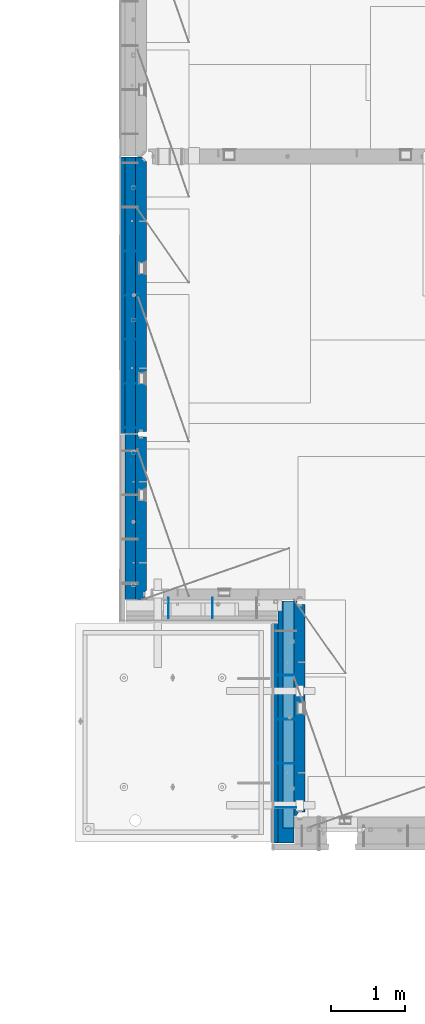
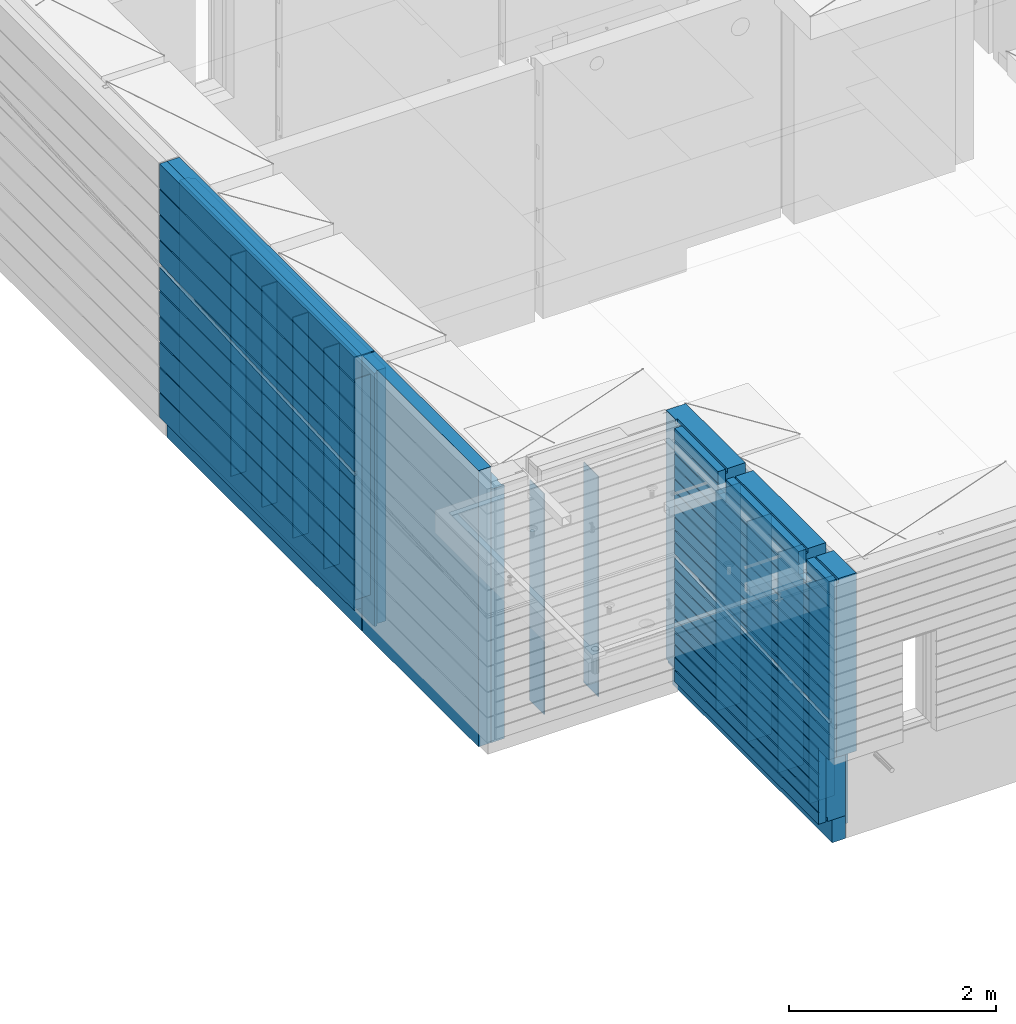
# One storey, part 208 of 325: 20 walls, 4 elements without a shape of their own.
"""IFC2X3 building model written with IfcOpenShell, lengths in millimetres."""

from ifc_helpers import new_model, si_unit, frame, origin_with_axes, place, context, subcontext, project, spatial, faceted_brep, material, type_object, element, aggregate, save


model = new_model("IFC2X3")

# Units and contexts
model_context = context("Model", 3, precision=1e-05, world=origin_with_axes())
body_context = subcontext(model_context, "Body", "Model", "MODEL_VIEW")
ifc_project = project(units=[si_unit("LENGTHUNIT", "METRE", prefix="MILLI"), si_unit("AREAUNIT", "SQUARE_METRE"), si_unit("VOLUMEUNIT", "CUBIC_METRE"), si_unit("MASSUNIT", "GRAM", prefix="KILO"), si_unit("TIMEUNIT", "SECOND"), si_unit("PLANEANGLEUNIT", "RADIAN"), si_unit("SOLIDANGLEUNIT", "STERADIAN"), si_unit("THERMODYNAMICTEMPERATUREUNIT", "DEGREE_CELSIUS"), si_unit("LUMINOUSINTENSITYUNIT", "LUMEN")], contexts=[model_context])

# Site, building, storey
site_placement = place(None, origin_with_axes())
site = spatial("IfcSite", under=ifc_project, at=site_placement, CompositionType="ELEMENT")
building_placement = place(site_placement, origin_with_axes())
building = spatial("IfcBuilding", under=site, at=building_placement, CompositionType="ELEMENT")
storey_placement = place(building_placement, origin_with_axes())
storey = spatial("IfcBuildingStorey", under=building, at=storey_placement, Name="1", CompositionType="ELEMENT", Elevation=0.0)

# Assembly, walls
assembly_1_placement = place(storey_placement, origin_with_axes())
assembly_1 = element("IfcElementAssembly", 1, at=assembly_1_placement, inside=storey, AssemblyPlace="NOTDEFINED", PredefinedType="REINFORCEMENT_UNIT")
ifc_material_1 = material(Name="Undefined")
wall_type_1 = type_object("IfcWallType", PredefinedType="NOTDEFINED")
wall_1_placement = place(assembly_1_placement, frame((7880.0, 15690.0, 83115.0), z_axis=(0.0, 0.0, 1.0), x_axis=(-1.0, 3.00000001838171e-08, 0.0)))
wall_1 = element("IfcWall", 2, at=wall_1_placement, type_object=wall_type_1, material=ifc_material_1, Name="(PD)", context=body_context, shape_type="Brep", body=[
    faceted_brep([(0.0, 5.0, -1300.0), (0.0, 5.0, 1300.0), (200.0, 5.0, 1300.0), (200.0, 5.0, -1300.0), (0.0, -5.0, 1300.0), (200.0, -5.0, 1300.0), (0.0, -5.0, -1300.0), (200.0, -5.0, -1300.0)], [[[0, 1, 2, 3]], [[1, 4, 5, 2]], [[4, 6, 7, 5]], [[6, 0, 3, 7]], [[5, 7, 3, 2]], [[6, 4, 1, 0]]]),
])
wall_2_placement = place(assembly_1_placement, frame((7880.0, 15090.0, 83115.0), z_axis=(0.0, 0.0, 1.0), x_axis=(-1.0, 3.00000001838171e-08, 0.0)))
wall_2 = element("IfcWall", 3, at=wall_2_placement, type_object=wall_type_1, material=ifc_material_1, Name="(PD)", context=body_context, shape_type="Brep", body=[
    faceted_brep([(0.0, 5.0, -1300.0), (0.0, 5.0, 1300.0), (200.0, 5.0, 1300.0), (200.0, 5.0, -1300.0), (0.0, -5.0, 1300.0), (200.0, -5.0, 1300.0), (0.0, -5.0, -1300.0), (200.0, -5.0, -1300.0)], [[[0, 1, 2, 3]], [[1, 4, 5, 2]], [[4, 6, 7, 5]], [[6, 0, 3, 7]], [[5, 7, 3, 2]], [[6, 4, 1, 0]]]),
])
wall_3_placement = place(assembly_1_placement, frame((7880.0, 14490.0, 83115.0), z_axis=(0.0, 0.0, 1.0), x_axis=(-1.0, 3.00000001838171e-08, 0.0)))
wall_3 = element("IfcWall", 4, at=wall_3_placement, type_object=wall_type_1, material=ifc_material_1, Name="(PD)", context=body_context, shape_type="Brep", body=[
    faceted_brep([(0.0, 5.0, -1300.0), (0.0, 5.0, 1300.0), (200.0, 5.0, 1300.0), (200.0, 5.0, -1300.0), (0.0, -5.0, 1300.0), (200.0, -5.0, 1300.0), (0.0, -5.0, -1300.0), (200.0, -5.0, -1300.0)], [[[0, 1, 2, 3]], [[1, 4, 5, 2]], [[4, 6, 7, 5]], [[6, 0, 3, 7]], [[5, 7, 3, 2]], [[6, 4, 1, 0]]]),
])
wall_4_placement = place(assembly_1_placement, frame((7880.0, 13890.0, 83115.0), z_axis=(0.0, 0.0, 1.0), x_axis=(-1.0, 3.00000001838171e-08, 0.0)))
wall_4 = element("IfcWall", 5, at=wall_4_placement, type_object=wall_type_1, material=ifc_material_1, Name="(PD)", context=body_context, shape_type="Brep", body=[
    faceted_brep([(0.0, 5.0, -1300.0), (0.0, 5.0, 1300.0), (200.0, 5.0, 1300.0), (200.0, 5.0, -1300.0), (0.0, -5.0, 1300.0), (200.0, -5.0, 1300.0), (0.0, -5.0, -1300.0), (200.0, -5.0, -1300.0)], [[[0, 1, 2, 3]], [[1, 4, 5, 2]], [[4, 6, 7, 5]], [[6, 0, 3, 7]], [[5, 7, 3, 2]], [[6, 4, 1, 0]]]),
])
wall_5_placement = place(assembly_1_placement, frame((7880.0, 13290.0, 83115.0), z_axis=(0.0, 0.0, 1.0), x_axis=(-1.0, 3.00000001838171e-08, 0.0)))
wall_5 = element("IfcWall", 6, at=wall_5_placement, type_object=wall_type_1, material=ifc_material_1, Name="(PD)", context=body_context, shape_type="Brep", body=[
    faceted_brep([(0.0, 5.0, -1300.0), (0.0, 5.0, 1300.0), (200.0, 5.0, 1300.0), (200.0, 5.0, -1300.0), (0.0, -5.0, 1300.0), (200.0, -5.0, 1300.0), (0.0, -5.0, -1300.0), (200.0, -5.0, -1300.0)], [[[0, 1, 2, 3]], [[1, 4, 5, 2]], [[4, 6, 7, 5]], [[6, 0, 3, 7]], [[5, 7, 3, 2]], [[6, 4, 1, 0]]]),
])

assembly_2_placement = place(storey_placement, origin_with_axes())
assembly_2 = element("IfcElementAssembly", 7, at=assembly_2_placement, inside=storey, AssemblyPlace="NOTDEFINED", PredefinedType="REINFORCEMENT_UNIT")
wall_6_placement = place(assembly_2_placement, frame((8300.0, 10980.0, 83115.0), z_axis=(0.0, 0.0, 1.0), x_axis=(0.0, -1.0, 0.0)))
wall_6 = element("IfcWall", 8, at=wall_6_placement, type_object=wall_type_1, material=ifc_material_1, Name="(PD)", context=body_context, shape_type="Brep", body=[
    faceted_brep([(0.0, 5.0, -1300.0), (0.0, 5.0, 1300.0), (280.0, 5.0, 1300.0), (280.0, 5.0, -1300.0), (0.0, -5.0, 1300.0), (280.0, -5.0, 1300.0), (0.0, -5.0, -1300.0), (280.0, -5.0, -1300.0)], [[[0, 1, 2, 3]], [[1, 4, 5, 2]], [[4, 6, 7, 5]], [[6, 0, 3, 7]], [[5, 7, 3, 2]], [[6, 4, 1, 0]]]),
])
wall_7_placement = place(assembly_2_placement, frame((8900.0, 10980.0, 83115.0), z_axis=(0.0, 0.0, 1.0), x_axis=(0.0, -1.0, 0.0)))
wall_7 = element("IfcWall", 9, at=wall_7_placement, type_object=wall_type_1, material=ifc_material_1, Name="(PD)", context=body_context, shape_type="Brep", body=[
    faceted_brep([(0.0, 5.0, -1300.0), (0.0, 5.0, 1300.0), (280.0, 5.0, 1300.0), (280.0, 5.0, -1300.0), (0.0, -5.0, 1300.0), (280.0, -5.0, 1300.0), (0.0, -5.0, -1300.0), (280.0, -5.0, -1300.0)], [[[0, 1, 2, 3]], [[1, 4, 5, 2]], [[4, 6, 7, 5]], [[6, 0, 3, 7]], [[5, 7, 3, 2]], [[6, 4, 1, 0]]]),
])
aggregate(assembly_2, [wall_6, wall_7])

assembly_3_placement = place(storey_placement, origin_with_axes())
assembly_3 = element("IfcElementAssembly", 10, at=assembly_3_placement, inside=storey, AssemblyPlace="NOTDEFINED", PredefinedType="REINFORCEMENT_UNIT")
wall_8_placement = place(assembly_3_placement, frame((10040.0, 9925.0, 83115.0), z_axis=(0.0, 0.0, 1.0), x_axis=(-1.0, 3.00000001838171e-08, 0.0)))
wall_8 = element("IfcWall", 11, at=wall_8_placement, type_object=wall_type_1, material=ifc_material_1, Name="(PD)", context=body_context, shape_type="Brep", body=[
    faceted_brep([(0.0, 5.0, -1300.0), (0.0, 5.0, 1300.0), (280.0, 5.0, 1300.0), (280.0, 5.0, -1300.0), (0.0, -5.0, 1300.0), (280.0, -5.0, 1300.0), (0.0, -5.0, -1300.0), (280.0, -5.0, -1300.0)], [[[0, 1, 2, 3]], [[1, 4, 5, 2]], [[4, 6, 7, 5]], [[6, 0, 3, 7]], [[5, 7, 3, 2]], [[6, 4, 1, 0]]]),
])
wall_9_placement = place(assembly_3_placement, frame((10040.0, 9325.0, 83115.0), z_axis=(0.0, 0.0, 1.0), x_axis=(-1.0, 3.00000001838171e-08, 0.0)))
wall_9 = element("IfcWall", 12, at=wall_9_placement, type_object=wall_type_1, material=ifc_material_1, Name="(PD)", context=body_context, shape_type="Brep", body=[
    faceted_brep([(0.0, 5.0, -1300.0), (0.0, 5.0, 1300.0), (280.0, 5.0, 1300.0), (280.0, 5.0, -1300.0), (0.0, -5.0, 1300.0), (280.0, -5.0, 1300.0), (0.0, -5.0, -1300.0), (280.0, -5.0, -1300.0)], [[[0, 1, 2, 3]], [[1, 4, 5, 2]], [[4, 6, 7, 5]], [[6, 0, 3, 7]], [[5, 7, 3, 2]], [[6, 4, 1, 0]]]),
])
wall_10_placement = place(assembly_3_placement, frame((10040.0, 8725.0, 83115.0), z_axis=(0.0, 0.0, 1.0), x_axis=(-1.0, 3.00000001838171e-08, 0.0)))
wall_10 = element("IfcWall", 13, at=wall_10_placement, type_object=wall_type_1, material=ifc_material_1, Name="(PD)", context=body_context, shape_type="Brep", body=[
    faceted_brep([(0.0, 5.0, -1300.0), (0.0, 5.0, 1300.0), (280.0, 5.0, 1300.0), (280.0, 5.0, -1300.0), (0.0, -5.0, 1300.0), (280.0, -5.0, 1300.0), (0.0, -5.0, -1300.0), (280.0, -5.0, -1300.0)], [[[0, 1, 2, 3]], [[1, 4, 5, 2]], [[4, 6, 7, 5]], [[6, 0, 3, 7]], [[5, 7, 3, 2]], [[6, 4, 1, 0]]]),
])
wall_11_placement = place(assembly_3_placement, frame((10040.0, 8125.0, 83115.0), z_axis=(0.0, 0.0, 1.0), x_axis=(-1.0, 3.00000001838171e-08, 0.0)))
wall_11 = element("IfcWall", 14, at=wall_11_placement, type_object=wall_type_1, material=ifc_material_1, Name="(PD)", context=body_context, shape_type="Brep", body=[
    faceted_brep([(0.0, 5.0, -1300.0), (0.0, 5.0, 1300.0), (280.0, 5.0, 1300.0), (280.0, 5.0, -1300.0), (0.0, -5.0, 1300.0), (280.0, -5.0, 1300.0), (0.0, -5.0, -1300.0), (280.0, -5.0, -1300.0)], [[[0, 1, 2, 3]], [[1, 4, 5, 2]], [[4, 6, 7, 5]], [[6, 0, 3, 7]], [[5, 7, 3, 2]], [[6, 4, 1, 0]]]),
])
ifc_material_2 = material(Name="COS5gt")
wall_type_2 = type_object("IfcWallType", PredefinedType="NOTDEFINED")
wall_12_placement = place(assembly_3_placement, frame((9900.0, 8000.0, 83247.5), z_axis=(0.0, 0.0, 1.0), x_axis=(0.0, 1.0, 0.0)))
wall_12 = element("IfcWall", 15, at=wall_12_placement, type_object=wall_type_2, material=ifc_material_2, context=body_context, shape_type="Brep", body=[
    faceted_brep([(-150.0, -110.0, -607.5), (-150.0, 110.0, -607.5), (-150.0, 110.0, -1442.5), (-150.0, 90.0, -1442.5), (-150.0, 90.0, -1492.5), (-150.0, -110.0, -1492.5), (-355.0, -110.0, -607.5), (-355.0, 110.0, -607.5), (2751.0, 90.0, 1492.5), (2751.0, 90.0, 1442.5), (1785.0, 90.0, 1442.5), (1785.0, 90.0, 1492.5), (2751.0, 110.0, 1492.5), (2751.0, 110.0, 1442.5), (1785.0, 110.0, 1442.5), (1635.0, -110.0, 1492.5), (1635.0, 90.0, 1492.5), (229.999999999998, 90.0, 1492.5), (229.999999999998, -110.0, 1492.5), (1635.0, 90.0, 1442.5), (1635.0, 110.0, 1442.5), (229.999999999998, 110.0, 1442.5), (229.999999999998, 90.0, 1442.5), (-355.0, 110.0, 1442.5), (-355.0, 90.0, 1442.5), (79.9999999999982, 90.0, 1442.5), (79.9999999999982, 110.0, 1442.5), (-355.0, 90.0, 1492.5), (-355.0, -110.0, 1492.5), (79.9999999999982, -110.0, 1492.5), (79.9999999999982, 90.0, 1492.5), (79.9999999999982, -110.0, 1222.5), (79.9999999999982, 110.0, 1222.5), (229.999999999998, -110.0, 1222.5), (229.999999999998, 110.0, 1222.5), (1635.0, -110.0, 1222.5), (1635.0, 110.0, 1222.5), (1785.0, -110.0, 1222.5), (1785.0, 110.0, 1222.5), (1785.0, -110.0, 1492.5), (2935.0, -110.0, 1492.5), (2935.0, 110.0, 1492.5), (2935.0, -110.0, -1492.5), (2935.0, 90.0, -1492.5), (2935.0, 90.0, -1442.5), (2935.0, 110.0, -1442.5)], [[[0, 1, 2, 3, 4, 5]], [[6, 7, 1, 0]], [[8, 9, 10, 11]], [[12, 13, 9, 8]], [[9, 13, 14, 10]], [[15, 16, 17, 18]], [[19, 20, 21, 22]], [[23, 24, 25, 26]], [[27, 28, 29, 30]], [[24, 27, 30, 25]], [[29, 31, 32, 26, 25, 30]], [[33, 34, 32, 31]], [[18, 17, 22, 21, 34, 33]], [[16, 19, 22, 17]], [[15, 35, 36, 20, 19, 16]], [[37, 38, 36, 35]], [[39, 11, 10, 14, 38, 37]], [[40, 41, 12, 8, 11, 39]], [[41, 40, 42, 43, 44, 45]], [[43, 42, 5, 4]], [[44, 43, 4, 3]], [[45, 44, 3, 2]], [[23, 26, 32, 34, 21, 20, 36, 38, 14, 13, 12, 41, 45, 2, 1, 7]], [[28, 27, 24, 23, 7, 6]], [[42, 40, 39, 37, 35, 15, 18, 33, 31, 29, 28, 6, 0, 5]]]),
])

# Wall
ifc_material_3 = material(Name="CONCRETE/C30/37")
wall_type_3 = type_object("IfcWallType", PredefinedType="NOTDEFINED")
wall_13_placement = place(assembly_1_placement, frame((7667.5, 13210.0, 83247.5), z_axis=(0.0, 0.0, 1.0), x_axis=(0.0, 1.0, 0.0)))
wall_13 = element("IfcWall", 16, at=wall_13_placement, type_object=wall_type_3, material=ifc_material_3, context=body_context, shape_type="Brep", body=[
    faceted_brep([(3759.9500004017, 42.5, 276.327823387459), (0.0, 42.5, 92.631582698581), (4.04732254537521e-05, 12.4999999999927, 92.631582698581), (3759.95000031049, 12.4999999999927, 276.327823387459), (3759.9500004017, 12.4999999999927, 326.327823080399), (9.0334564447403e-05, 12.4999999999927, 142.631584822841), (0.0, 42.5, 142.631584822841), (3077.78608245648, 42.5, 292.999999944761), (3118.72268571102, 32.4999992501689, 294.999999999229), (3323.40570462213, 32.4999991121731, 305.00000040044), (3364.34229629902, 42.5, 306.999999889245), (3759.9500004017, 42.5, 326.327823080399), (3759.9500004017, 32.4999991121731, 5.0000004004396), (0.0, 32.4999991127006, 5.0000004004396), (0.0, 42.5, 6.99999988924537), (3759.9500004017, 42.5, 6.99999988924537), (3759.9500004017, 32.4999992501689, -5.00000000077125), (0.0, 32.4999992507037, -5.00000000074215), (3759.9500004017, 42.5, -7.00000005523907), (0.0, 42.5, -7.00000005523907), (3759.9500004017, 42.5, -293.000000110755), (0.0, 42.5, -293.000000110755), (3759.9500004017, 32.4999991121731, -294.99999959956), (0.0, 32.4999991127006, -294.99999959956), (3759.9500004017, 32.4999992501689, -305.000000000771), (0.0, 32.4999992507037, -305.000000000742), (3759.9500004017, 42.5, -307.000000055239), (0.0, 42.5, -307.000000055239), (3759.9500004017, 42.5, -593.000000110755), (0.0, 42.5, -593.000000110755), (3759.9500004017, 32.4999991121731, -594.99999959956), (3.63797880709171e-12, 32.4999991127006, -594.99999959956), (3759.9500004017, 32.4999992501689, -605.000000000771), (3.63797880709171e-12, 32.4999992507037, -605.000000000742), (3759.9500004017, 42.5, -607.000000055239), (0.0, 42.5, -607.000000055239), (3759.9500004017, 42.5, -893.000000110755), (0.0, 42.5, -893.000000110755), (3759.9500004017, 32.4999991121731, -894.99999959956), (0.0, 32.4999991127006, -894.99999959956), (3759.9500004017, 32.4999992501689, -905.000000000771), (0.0, 32.4999992507037, -905.000000000742), (3759.9500004017, 42.5, -907.000000055239), (0.0, 42.5, -907.000000055239), (3759.9500004017, 42.5, -1193.00000011075), (0.0, 42.5, -1193.00000011075), (3759.9500004017, 32.4999991121731, -1194.99999959956), (0.0, 32.4999991127006, -1194.99999959956), (3759.9500004017, 32.4999992501689, -1205.00000000077), (0.0, 32.4999992507037, -1205.00000000074), (3759.9500004017, 42.5, -1207.00000005524), (0.0, 42.5, -1207.00000005524), (3759.9500004017, 42.5, -1492.5), (0.0, 42.5, -1492.5), (0.0, -42.5, -1492.5), (3759.9500004017, -42.5, -1492.5), (0.0, -42.5, 1492.5), (3759.9500004017, -42.5, 1492.5), (0.0, 42.5, 1492.5), (3759.9500004017, 42.5, 1492.5), (3759.9500004017, 42.5, 1206.99999988925), (0.0, 42.5, 1206.99999988925), (3759.9500004017, 32.4999991121731, 1205.00000040044), (0.0, 32.4999991127006, 1205.00000040044), (3759.9500004017, 32.4999992501689, 1194.99999999923), (0.0, 32.4999992507037, 1194.99999999926), (3759.9500004017, 42.5, 1192.99999994476), (0.0, 42.5, 1192.99999994476), (3759.9500004017, 42.5, 906.999999889245), (0.0, 42.5, 906.999999889245), (3759.9500004017, 32.4999991121731, 905.00000040044), (0.0, 32.4999991127006, 905.00000040044), (3759.9500004017, 32.4999992501689, 894.999999999229), (0.0, 32.4999992507037, 894.999999999258), (3759.9500004017, 42.5, 892.999999944761), (0.0, 42.5, 892.999999944761), (3759.9500004017, 42.5, 606.999999889245), (0.0, 42.5, 606.999999889245), (3759.9500004017, 32.4999991121731, 605.00000040044), (3.63797880709171e-12, 32.4999991127006, 605.00000040044), (3759.9500004017, 32.4999992501689, 594.999999999229), (3.63797880709171e-12, 32.4999992507037, 594.999999999258), (3759.9500004017, 42.5, 592.999999944761), (0.0, 42.5, 592.999999944761), (0.0, 42.5, 306.999999889245), (-3.63797880709171e-12, 32.4999991127006, 305.00000040044), (-3.63797880709171e-12, 32.4999992507037, 294.999999999258), (0.0, 42.5, 292.999999944761)], [[[0, 1, 2, 3]], [[4, 5, 6, 7, 8, 9, 10, 11]], [[3, 2, 5, 4]], [[12, 13, 14, 15]], [[16, 17, 13, 12]], [[18, 19, 17, 16]], [[20, 21, 19, 18]], [[22, 23, 21, 20]], [[24, 25, 23, 22]], [[26, 27, 25, 24]], [[28, 29, 27, 26]], [[30, 31, 29, 28]], [[32, 33, 31, 30]], [[34, 35, 33, 32]], [[36, 37, 35, 34]], [[38, 39, 37, 36]], [[40, 41, 39, 38]], [[42, 43, 41, 40]], [[44, 45, 43, 42]], [[46, 47, 45, 44]], [[48, 49, 47, 46]], [[50, 51, 49, 48]], [[52, 53, 51, 50]], [[54, 53, 52, 55]], [[56, 54, 55, 57]], [[58, 56, 57, 59]], [[58, 59, 60, 61]], [[62, 63, 61, 60]], [[64, 65, 63, 62]], [[66, 67, 65, 64]], [[68, 69, 67, 66]], [[70, 71, 69, 68]], [[72, 73, 71, 70]], [[74, 75, 73, 72]], [[76, 77, 75, 74]], [[78, 79, 77, 76]], [[80, 81, 79, 78]], [[82, 83, 81, 80]], [[84, 83, 82, 11, 10]], [[85, 84, 10, 9]], [[86, 85, 9, 8]], [[87, 86, 8, 7]], [[87, 7, 6]], [[1, 14, 13, 17, 19, 21, 23, 25, 27, 29, 31, 33, 35, 37, 39, 41, 43, 45, 47, 49, 51, 53, 54, 56, 58, 61, 63, 65, 67, 69, 71, 73, 75, 77, 79, 81, 83, 84, 85, 86, 87, 6, 5, 2]], [[15, 14, 1, 0]], [[82, 80, 78, 76, 74, 72, 70, 68, 66, 64, 62, 60, 59, 57, 55, 52, 50, 48, 46, 44, 42, 40, 38, 36, 34, 32, 30, 28, 26, 24, 22, 20, 18, 16, 12, 15, 0, 3, 4, 11]]]),
])

wall_14_placement = place(assembly_3_placement, frame((9747.5, 8000.0, 83247.5), z_axis=(0.0, 0.0, 1.0), x_axis=(0.0, 1.0, 0.0)))
wall_14 = element("IfcWall", 17, at=wall_14_placement, type_object=wall_type_3, material=ifc_material_3, context=body_context, shape_type="Brep", body=[
    faceted_brep([(2630.0, 42.5, -33.4213325430028), (386.991957076316, 42.5, -143.000000110769), (346.053195555138, 32.4999991164314, -144.999999599575), (141.359327417116, 32.4999992544253, -155.0000000008), (100.420554317418, 42.5, -157.000000055254), (-355.0, 42.5, -179.248862550885), (-354.999999999999, 12.4999999999982, -179.248862550885), (2630.00000006686, 12.4999999999982, -33.4213325430028), (2630.0, 12.4999999999982, 16.5473755983112), (-354.999999999999, 12.4999999999982, -129.249877626527), (-355.0, 42.5, -129.249877626527), (2147.89958472361, 42.5, -7.00000005523907), (2188.84685931518, 32.4999992500489, -5.00000000080036), (2393.58323491501, 32.4999991120476, 5.00000040042505), (2434.53049792634, 42.5, 6.99999988924537), (2630.0, 42.5, 16.5786657067802), (-355.0, 42.5, 1342.99999994476), (-355.0, 32.4999992499324, 1344.99999999921), (79.9999999999982, 32.4999992499324, 1344.99999999921), (79.9999999999982, 42.5, 1342.99999994476), (-355.0, 32.4999991119385, 1355.00000040044), (79.9999999999982, 32.4999991119385, 1355.00000040044), (-355.0, 42.5, 1356.99999988925), (79.9999999999982, 42.5, 1356.99999988925), (2630.0, -42.5, 1492.5), (2630.0, 42.5, 1492.5), (1785.0, 42.5, 1492.5), (1785.0, -42.5, 1492.5), (2630.0, 42.5, 1356.99999988925), (1785.0, 42.5, 1356.99999988925), (2630.0, 32.4999991119385, 1355.00000040044), (1785.0, 32.4999991119385, 1355.00000040044), (2630.0, 32.4999992499324, 1344.99999999921), (1785.0, 32.4999992499324, 1344.99999999921), (2630.0, 42.5, 1342.99999994476), (1785.0, 42.5, 1342.99999994476), (1785.0, 42.5, 1222.5), (1785.0, -42.5, 1222.5), (1635.0, 42.5, 1222.5), (1635.0, -42.5, 1222.5), (1635.0, -42.5, 1492.5), (1635.0, 42.5, 1342.99999994476), (1635.0, 32.4999992499324, 1344.99999999921), (1635.0, 32.4999991119385, 1355.00000040044), (1635.0, 42.5, 1356.99999988925), (1635.0, 42.5, 1492.5), (229.999999999998, 42.5, 1342.99999994476), (229.999999999998, 32.4999992499324, 1344.99999999921), (229.999999999998, 32.4999991119385, 1355.00000040044), (229.999999999998, 42.5, 1356.99999988925), (229.999999999998, 42.5, 1492.5), (229.999999999998, -42.5, 1492.5), (2630.0, 32.4999991158911, -294.999999599575), (-355.0, 32.4999991158911, -294.999999599575), (-355.0, 42.5, -293.000000110755), (2630.0, 42.5, -293.000000110755), (2630.0, 32.4999992538942, -305.0000000008), (-355.0, 32.4999992538942, -305.0000000008), (2630.0, 42.5, -307.000000055239), (-355.0, 42.5, -307.000000055239), (2630.0, 42.5, -443.00000011074), (-355.0, 42.5, -443.00000011074), (2630.0, 32.499999114294, -444.99999959956), (-355.000000000001, 32.499999114294, -444.99999959956), (2630.0, 32.4999992522953, -455.000000000786), (-355.000000000001, 32.4999992522953, -455.000000000786), (2630.0, 42.5, -457.000000055225), (-355.0, 42.5, -457.000000055225), (-150.0, 42.4999992447574, -593.00000011074), (-150.0, 32.4999991142904, -594.99999959956), (-150.0, 32.4999992523008, -605.000000000757), (-150.0, 42.4999992696412, -607.000000055225), (2630.0, 32.499999114294, -594.99999959956), (2630.0, 42.5, -593.00000011074), (2630.0, 32.4999992522953, -605.000000000786), (2630.0, 42.5, -607.000000055225), (-355.0, -42.5, -607.5), (-355.0, 42.5, -607.5), (-150.000000000005, 42.4999997380673, -607.5), (-150.000000000005, -42.5, -607.5), (2630.0, 42.5, -743.00000011074), (-150.000000000005, 42.4999992461126, -743.00000011074), (2630.0, 32.499999114294, -744.99999959956), (-150.000000000005, 32.4999991142904, -744.99999959956), (2630.0, 32.4999992522953, -755.000000000786), (-150.000000000005, 32.4999992523008, -755.000000000757), (2630.0, 42.5, -757.000000055225), (-150.000000000005, 42.4999992709527, -757.000000055225), (2630.0, 42.5, -893.00000011074), (-150.000000000005, 42.4999992456051, -893.00000011074), (2630.0, 32.4999991137665, -894.99999959956), (-150.000000000005, 32.4999991137774, -894.999999599546), (2630.0, 32.4999992517678, -905.000000000786), (-150.000000000005, 32.4999992517769, -905.000000000742), (2630.0, 42.5, -907.000000055225), (-150.000000000005, 42.4999992704252, -907.000000055225), (2630.0, 42.5, -1043.00000011077), (-150.000000000005, 42.4999992450466, -1043.00000011077), (2630.0, 32.4999991132281, -1044.99999959959), (-150.000000000005, 32.4999991132208, -1044.99999959959), (2630.0, 32.4999992512294, -1055.00000000081), (-150.000000000005, 32.499999251233, -1055.00000000079), (2630.0, 42.5, -1057.00000005525), (-150.000000000005, 42.4999992698868, -1057.00000005525), (2630.0, 42.5, -1193.00000011075), (-150.000000000005, 42.4999992445264, -1193.00000011075), (2630.0, 32.4999991126915, -1194.99999959957), (-150.000000000005, 32.4999991126988, -1194.99999959956), (2630.0, 32.4999992506928, -1205.0000000008), (-150.000000000005, 32.4999992506982, -1205.00000000076), (2630.0, 42.5, -1207.00000005524), (-150.000000000005, 42.4999992693502, -1207.00000005524), (2630.0, 42.5, -1343.00000011075), (-150.000000000005, 42.4999992445264, -1343.00000011075), (2630.0, 32.4999991126915, -1344.99999959957), (-150.000000000005, 32.4999991126988, -1344.99999959956), (2630.0, 32.4999992506928, -1355.0000000008), (-150.000000000005, 32.4999992506982, -1355.00000000076), (2630.0, 42.5, -1357.00000005524), (-150.000000000005, 42.4999992693502, -1357.00000005524), (2630.0, 42.5, -1492.5), (-150.000000000005, 42.5, -1492.5), (2630.0, -42.5, -1492.5), (-150.000000000005, -42.5, -1492.5), (229.999999999998, -42.5, 1222.5), (79.9999999999982, -42.5, 1222.5), (79.9999999999982, -42.5, 1492.5), (-355.0, -42.5, 1492.5), (-355.0, 42.5, 1492.5), (79.9999999999982, 42.5, 1492.5), (79.9999999999982, 42.5, 1222.5), (229.999999999998, 42.5, 1222.5), (2630.0, 42.5, 1206.99999988925), (-355.0, 42.5, 1206.99999988925), (2630.0, 32.499999111953, 1205.00000040044), (-355.0, 32.499999111953, 1205.00000040044), (2630.0, 32.499999249947, 1194.99999999921), (-355.0, 32.499999249947, 1194.99999999921), (2630.0, 42.5, 1192.99999994476), (-355.0, 42.5, 1192.99999994476), (2630.0, 42.5, 1056.99999988925), (-355.0, 42.5, 1056.99999988925), (2630.0, 32.4999991119657, 1055.00000040044), (-355.0, 32.4999991119657, 1055.00000040044), (2630.0, 32.4999992499597, 1044.99999999921), (-355.0, 32.4999992499597, 1044.99999999921), (2630.0, 42.5, 1042.99999994476), (-355.0, 42.5, 1042.99999994476), (2630.0, 42.5, 906.999999889245), (-355.0, 42.5, 906.999999889245), (2630.0, 32.4999991119785, 905.00000040044), (-354.999999999999, 32.4999991119785, 905.00000040044), (2630.0, 32.4999992499725, 894.999999999214), (-354.999999999999, 32.4999992499725, 894.999999999214), (2630.0, 42.5, 892.999999944761), (-355.0, 42.5, 892.999999944761), (2630.0, 42.5, 756.999999889245), (-355.0, 42.5, 756.999999889245), (2630.0, 32.4999991119912, 755.00000040044), (-354.999999999999, 32.4999991119912, 755.00000040044), (2630.0, 32.4999992499852, 744.999999999214), (-354.999999999999, 32.4999992499852, 744.999999999214), (2630.0, 42.5, 742.999999944761), (-355.0, 42.5, 742.999999944761), (2630.0, 42.5, 606.999999889245), (-355.0, 42.5, 606.999999889245), (2630.0, 32.4999991120039, 605.00000040044), (-355.0, 32.4999991120039, 605.00000040044), (2630.0, 32.4999992499979, 594.999999999214), (-355.0, 32.4999992499979, 594.999999999214), (2630.0, 42.5, 592.999999944761), (-355.0, 42.5, 592.999999944761), (2630.0, 42.5, 456.999999889245), (-355.0, 42.5, 456.999999889245), (2630.0, 32.4999991120167, 455.00000040044), (-355.0, 32.4999991120167, 455.00000040044), (2630.0, 32.4999992500107, 444.999999999214), (-355.0, 32.4999992500107, 444.999999999214), (2630.0, 42.5, 442.999999944761), (-355.0, 42.5, 442.999999944761), (2630.0, 42.5, 306.999999889245), (-355.0, 42.5, 306.999999889245), (2630.0, 32.4999991120294, 305.00000040044), (-355.0, 32.4999991120294, 305.00000040044), (2630.0, 32.4999992500234, 294.999999999214), (-355.0, 32.4999992500234, 294.999999999214), (2630.0, 42.5, 292.999999944761), (-355.0, 42.5, 292.999999944761), (2630.0, 42.5, 156.999999889245), (-355.0, 42.5, 156.999999889245), (2630.0, 32.4999991120421, 155.00000040044), (-355.0, 32.4999991120421, 155.00000040044), (2630.0, 32.4999992500361, 144.999999999214), (-355.0, 32.4999992500361, 144.999999999214), (2630.0, 42.5, 142.999999944761), (-355.0, 42.5, 142.999999944761), (-355.0, 42.5, 6.99999988924537), (-355.0, 32.4999991120549, 5.0000004004396), (-355.0, 32.4999992500489, -5.0000000007858), (-355.0, 42.5, -7.00000005523907), (2630.0, 42.5, -157.000000055254), (2630.0, 32.4999992544235, -155.000000000815), (2630.0, 32.4999991164223, -144.99999959959), (2630.0, 42.5, -143.000000110769)], [[[0, 1, 2, 3, 4, 5, 6, 7]], [[8, 9, 10, 11, 12, 13, 14, 15]], [[7, 6, 9, 8]], [[16, 17, 18, 19]], [[17, 20, 21, 18]], [[20, 22, 23, 21]], [[24, 25, 26, 27]], [[25, 28, 29, 26]], [[28, 30, 31, 29]], [[30, 32, 33, 31]], [[32, 34, 35, 33]], [[27, 26, 29, 31, 33, 35, 36, 37]], [[37, 36, 38, 39]], [[40, 39, 38, 41, 42, 43, 44, 45]], [[42, 41, 46, 47]], [[43, 42, 47, 48]], [[44, 43, 48, 49]], [[45, 44, 49, 50]], [[40, 45, 50, 51]], [[52, 53, 54, 55]], [[56, 57, 53, 52]], [[58, 59, 57, 56]], [[59, 58, 60, 61]], [[62, 63, 61, 60]], [[64, 65, 63, 62]], [[66, 67, 65, 64]], [[68, 69, 70, 71]], [[72, 69, 68, 73]], [[74, 70, 69, 72]], [[75, 71, 70, 74]], [[76, 77, 78, 79]], [[67, 66, 73, 68, 71, 75, 80, 81, 78, 77]], [[80, 82, 83, 81]], [[82, 84, 85, 83]], [[84, 86, 87, 85]], [[86, 88, 89, 87]], [[88, 90, 91, 89]], [[90, 92, 93, 91]], [[92, 94, 95, 93]], [[94, 96, 97, 95]], [[96, 98, 99, 97]], [[98, 100, 101, 99]], [[100, 102, 103, 101]], [[102, 104, 105, 103]], [[104, 106, 107, 105]], [[106, 108, 109, 107]], [[108, 110, 111, 109]], [[110, 112, 113, 111]], [[112, 114, 115, 113]], [[114, 116, 117, 115]], [[116, 118, 119, 117]], [[118, 120, 121, 119]], [[120, 122, 123, 121]], [[79, 78, 81, 83, 85, 87, 89, 91, 93, 95, 97, 99, 101, 103, 105, 107, 109, 111, 113, 115, 117, 119, 121, 123]], [[122, 24, 27, 37, 39, 40, 51, 124, 125, 126, 127, 76, 79, 123]], [[128, 127, 126, 129]], [[22, 128, 129, 23]], [[126, 125, 130, 19, 18, 21, 23, 129]], [[124, 131, 130, 125]], [[51, 50, 49, 48, 47, 46, 131, 124]], [[41, 38, 36, 35, 34, 132, 133, 16, 19, 130, 131, 46]], [[134, 135, 133, 132]], [[136, 137, 135, 134]], [[138, 139, 137, 136]], [[140, 141, 139, 138]], [[142, 143, 141, 140]], [[144, 145, 143, 142]], [[146, 147, 145, 144]], [[148, 149, 147, 146]], [[150, 151, 149, 148]], [[152, 153, 151, 150]], [[154, 155, 153, 152]], [[156, 157, 155, 154]], [[158, 159, 157, 156]], [[160, 161, 159, 158]], [[162, 163, 161, 160]], [[164, 165, 163, 162]], [[166, 167, 165, 164]], [[168, 169, 167, 166]], [[170, 171, 169, 168]], [[172, 173, 171, 170]], [[174, 175, 173, 172]], [[176, 177, 175, 174]], [[178, 179, 177, 176]], [[180, 181, 179, 178]], [[182, 183, 181, 180]], [[184, 185, 183, 182]], [[186, 187, 185, 184]], [[188, 189, 187, 186]], [[190, 191, 189, 188]], [[192, 193, 191, 190]], [[194, 195, 193, 192]], [[196, 195, 194, 15, 14]], [[197, 196, 14, 13]], [[198, 197, 13, 12]], [[199, 198, 12, 11]], [[199, 11, 10]], [[5, 54, 53, 57, 59, 61, 63, 65, 67, 77, 76, 127, 128, 22, 20, 17, 16, 133, 135, 137, 139, 141, 143, 145, 147, 149, 151, 153, 155, 157, 159, 161, 163, 165, 167, 169, 171, 173, 175, 177, 179, 181, 183, 185, 187, 189, 191, 193, 195, 196, 197, 198, 199, 10, 9, 6]], [[200, 55, 54, 5, 4]], [[201, 200, 4, 3]], [[202, 201, 3, 2]], [[203, 202, 2, 1]], [[203, 1, 0]], [[194, 192, 190, 188, 186, 184, 182, 180, 178, 176, 174, 172, 170, 168, 166, 164, 162, 160, 158, 156, 154, 152, 150, 148, 146, 144, 142, 140, 138, 136, 134, 132, 34, 32, 30, 28, 25, 24, 122, 120, 118, 116, 114, 112, 110, 108, 106, 104, 102, 100, 98, 96, 94, 92, 90, 88, 86, 84, 82, 80, 75, 74, 72, 73, 66, 64, 62, 60, 58, 56, 52, 55, 200, 201, 202, 203, 0, 7, 8, 15]]]),
])

ifc_material_4 = material(Name="CONCRETE/C25/30")
wall_type_4 = type_object("IfcWallType", PredefinedType="NOTDEFINED")
wall_15_placement = place(assembly_1_placement, frame((7925.0, 13202.5, 82977.5), z_axis=(0.0, 0.0, 1.0), x_axis=(0.0, 1.0, 0.0)))
wall_15 = element("IfcWall", 18, at=wall_15_placement, type_object=wall_type_4, material=ifc_material_4, context=body_context, shape_type="Brep", body=[
    faceted_brep([(7.5, 45.0, 1492.5), (7.5, 45.0, -1492.5), (37.5, 32.0, -1492.5), (37.5, 32.0, 1492.5), (37.5, -75.0, 1492.5), (37.5, -75.0, -1492.5), (7.5, 75.0, -1492.5), (7.5, 75.0, 1492.5), (3767.4500004017, 75.0, 1492.5), (3767.4500004017, 75.0, -1492.5), (3767.4500004017, -15.0, 1492.5), (3767.4500004017, -15.0, -1492.5), (3707.4500004017, -75.0, 1492.5), (3707.4500004017, -75.0, -1492.5)], [[[0, 1, 2, 3]], [[4, 3, 2, 5]], [[6, 7, 8, 9]], [[9, 8, 10, 11]], [[12, 13, 11, 10]], [[13, 12, 4, 5]], [[1, 6, 9, 11, 13, 5, 2]], [[7, 6, 1, 0]], [[12, 10, 8, 7, 0, 3, 4]]]),
])

# Assembly, wall
assembly_4_placement = place(storey_placement, origin_with_axes())
assembly_4 = element("IfcElementAssembly", 19, at=assembly_4_placement, inside=storey, AssemblyPlace="NOTDEFINED", PredefinedType="REINFORCEMENT_UNIT")
wall_16_placement = place(assembly_4_placement, frame((7925.0, 10955.0, 82977.5), z_axis=(0.0, 0.0, 1.0), x_axis=(0.0, 1.0, 0.0)))
wall_16 = element("IfcWall", 20, at=wall_16_placement, type_object=wall_type_4, material=ifc_material_4, context=body_context, shape_type="Brep", body=[
    faceted_brep([(2210.0, 32.0, 1492.5), (2210.0, 32.0, -1492.5), (2240.0, 45.0, -1492.5), (2240.0, 45.0, 1492.5), (2210.0, -75.0, 1492.5), (2210.0, -75.0, -1492.5), (0.0, 75.0, -1492.5), (0.0, 75.0, 1492.5), (2240.0, 75.0, 1492.5), (2240.0, 75.0, -1492.5), (0.0, -75.0, -1492.5), (0.0, -75.0, 1492.5), (17.0000000000018, -75.0, -1492.5), (17.0000000000018, -75.0, 1492.5), (30.0, -55.0, -1492.5), (30.0, -55.0, 1492.5), (110.0, -55.0, -1492.5), (110.0, -55.0, 1492.5), (123.0, -75.0, 1492.5), (123.0, -75.0, -1492.5)], [[[0, 1, 2, 3]], [[4, 5, 1, 0]], [[6, 7, 8, 9]], [[10, 11, 7, 6]], [[11, 10, 12, 13]], [[13, 12, 14, 15]], [[15, 14, 16, 17]], [[18, 17, 16, 19]], [[3, 8, 7, 11, 13, 15, 17, 18, 4, 0]], [[9, 8, 3, 2]], [[19, 16, 14, 12, 10, 6, 9, 2, 1, 5]], [[18, 19, 5, 4]]]),
])

# Wall
wall_17_placement = place(assembly_3_placement, frame((10085.0, 8000.0, 82977.5), z_axis=(0.0, 0.0, 1.0), x_axis=(0.0, 1.0, 0.0)))
wall_17 = element("IfcWall", 21, at=wall_17_placement, type_object=wall_type_4, material=ifc_material_4, context=body_context, shape_type="Brep", body=[
    faceted_brep([(2885.0, 27.0, -1222.5), (2885.0, 27.0, -1492.5), (2934.99999772087, 40.0, -1492.5), (2935.0, 40.0, -1222.5), (2885.0, -75.0, -1222.5), (2885.0, -75.0, -1492.5), (15.0, 45.0000000000036, 1492.5), (15.0, 45.0, 1222.5), (15.0, 45.0, -1222.5), (65.0, 15.0, -1222.5), (65.0, 15.0, 1222.5), (65.0, 15.0, 1492.5), (15.0, 75.0, -1492.5), (15.0, 75.0, 1492.5), (2934.99999772087, 75.0, 1492.5), (2934.99999772087, 75.0, -1492.5), (15.0, 45.0000000000036, -1492.5), (65.0, 15.0, -1492.5), (65.0, -75.0, -1222.5), (65.0, -75.0, -1492.5), (65.0, -75.0, 1222.5), (65.0, -75.0, 1492.5), (2934.99999772087, 40.0, 1492.5), (2885.0, -75.0, 1492.5), (2885.0, 27.0, 1492.5), (2885.0, -75.0, 1222.5), (2885.0, 27.0, 1222.5), (2934.99999794752, 40.0, 1222.5)], [[[0, 1, 2, 3]], [[4, 5, 1, 0]], [[6, 7, 8, 9, 10, 11]], [[12, 13, 14, 15]], [[7, 6, 13, 12, 16, 8]], [[8, 16, 17, 9]], [[18, 9, 17, 19]], [[20, 21, 11, 10, 9, 18]], [[22, 14, 13, 6, 11, 21, 23, 24]], [[24, 23, 25, 4, 0, 26]], [[24, 26, 0, 3, 27, 22]], [[15, 14, 22, 27, 3, 2]], [[19, 17, 16, 12, 15, 2, 1, 5]], [[25, 23, 21, 20, 18, 19, 5, 4]]]),
])

ifc_material_5 = material(Name="SPU")
wall_type_5 = type_object("IfcWallType", PredefinedType="NOTDEFINED")
wall_18_placement = place(assembly_3_placement, frame((9935.0, 7850.0, 81620.0), z_axis=(0.0, 0.0, 1.0), x_axis=(0.0, 1.0, 0.0)))
wall_18 = element("IfcWall", 22, at=wall_18_placement, type_object=wall_type_5, material=ifc_material_5, context=body_context, shape_type="Brep", body=[
    faceted_brep([(0.0, 75.0, -135.0), (0.0, 75.0, 135.0), (3084.99999772087, 75.0, 135.0), (3084.99999772087, 75.0, -135.0), (0.0, -75.0, 135.0), (3084.99999772087, -75.0, 135.0), (0.0, -75.0, -135.0), (3084.99999772087, -75.0, -135.0)], [[[0, 1, 2, 3]], [[1, 4, 5, 2]], [[4, 6, 7, 5]], [[6, 0, 3, 7]], [[5, 7, 3, 2]], [[6, 4, 1, 0]]]),
])

aggregate(assembly_3, [wall_8, wall_9, wall_10, wall_18, wall_11, wall_12, wall_14, wall_17])

wall_type_6 = type_object("IfcWallType", PredefinedType="NOTDEFINED")
wall_19_placement = place(assembly_1_placement, frame((7780.0, 13210.0, 83112.5), z_axis=(0.0, 0.0, 1.0), x_axis=(0.0, 1.0, 0.0)))
wall_19 = element("IfcWall", 23, at=wall_19_placement, type_object=wall_type_6, material=ifc_material_5, context=body_context, shape_type="Brep", body=[
    faceted_brep([(0.0, 70.0, -1627.5), (0.0, 70.0, 1627.5), (3759.9500004017, 70.0, 1627.5), (3759.9500004017, 70.0, -1627.5), (0.0, -70.0, 1627.5), (3759.9500004017, -70.0, 1627.5), (0.0, -70.0, -1627.5), (3759.9500004017, -70.0, -1627.5)], [[[0, 1, 2, 3]], [[1, 4, 5, 2]], [[4, 6, 7, 5]], [[6, 0, 3, 7]], [[5, 7, 3, 2]], [[6, 4, 1, 0]]]),
])

aggregate(assembly_1, [wall_1, wall_2, wall_3, wall_4, wall_5, wall_13, wall_19, wall_15])

wall_20_placement = place(assembly_4_placement, frame((7780.0, 10955.0, 83112.5), z_axis=(0.0, 0.0, 1.0), x_axis=(0.0, 1.0, 0.0)))
wall_20 = element("IfcWall", 24, at=wall_20_placement, type_object=wall_type_6, material=ifc_material_5, context=body_context, shape_type="Brep", body=[
    faceted_brep([(0.0, 70.0, -1627.5), (0.0, 70.0, 1627.5), (2240.0, 70.0, 1627.5), (2240.0, 70.0, -1627.5), (0.0, -70.0, 1627.5), (2240.0, -70.0, 1627.5), (0.0, -70.0, -1627.5), (2240.0, -70.0, -1627.5)], [[[0, 1, 2, 3]], [[1, 4, 5, 2]], [[4, 6, 7, 5]], [[6, 0, 3, 7]], [[5, 7, 3, 2]], [[6, 4, 1, 0]]]),
])

aggregate(assembly_4, [wall_20, wall_16])

save(model, "model.ifc")
